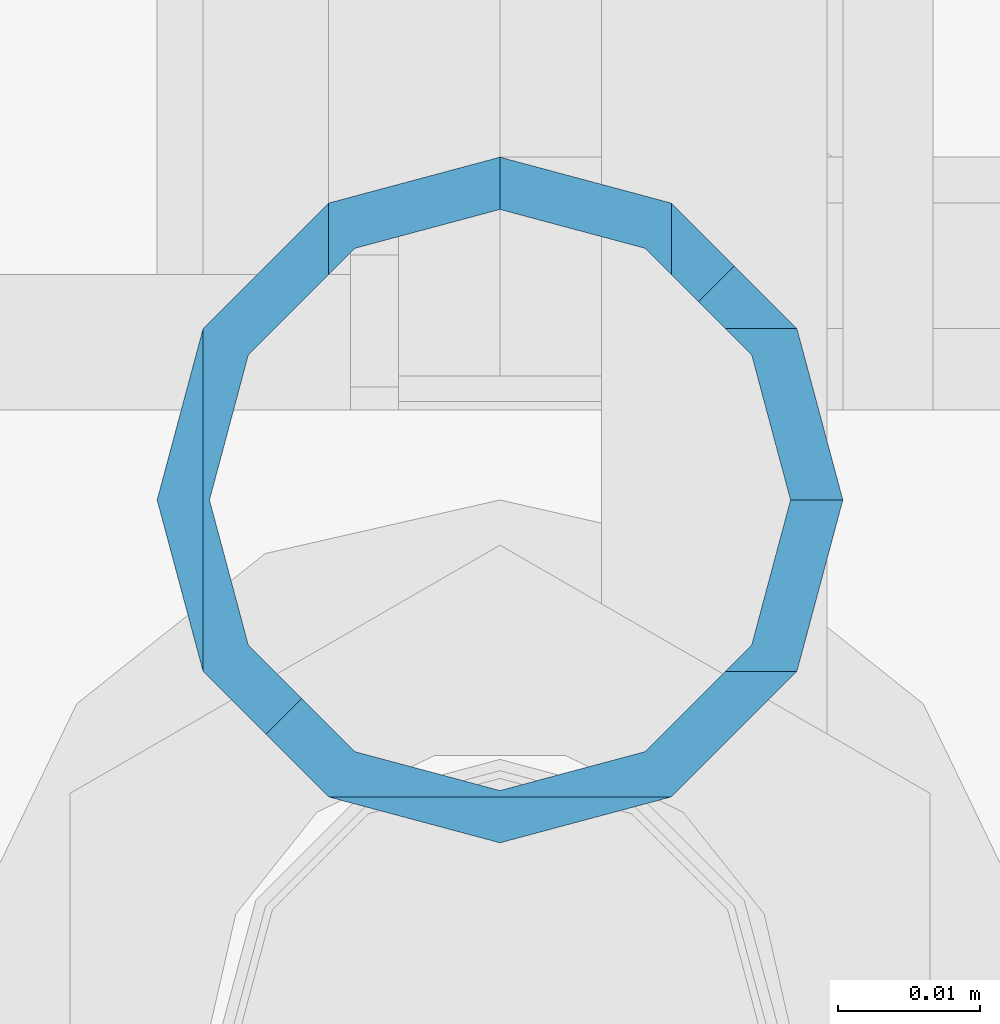
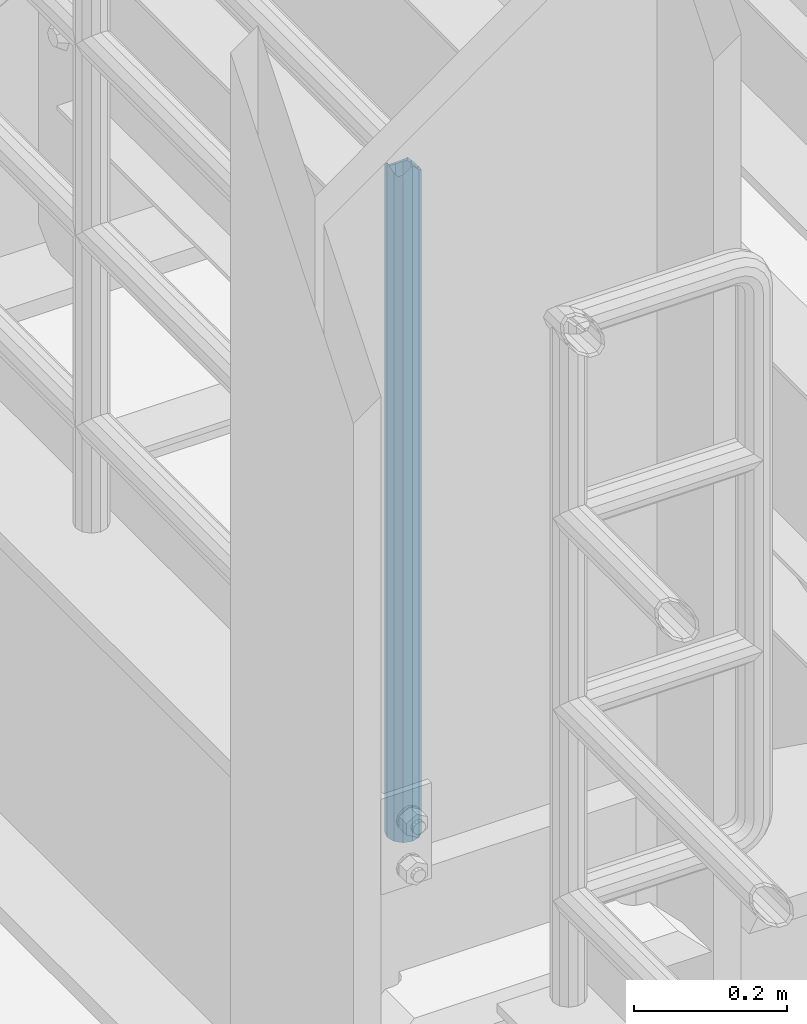
# One storey, part 596 of 1876: 1 column, 1 element without a shape of its own.
"""IFC2X3 building model written with IfcOpenShell, lengths in millimetres."""

from ifc_helpers import new_model, si_unit, frame, origin_with_axes, place, context, subcontext, project, spatial, faceted_brep, material, type_object, element, aggregate, save


model = new_model("IFC2X3")

# Units and contexts
model_context = context("Model", 3, precision=1e-05, world=origin_with_axes())
body_context = subcontext(model_context, "Body", "Model", "MODEL_VIEW")
ifc_project = project(units=[si_unit("LENGTHUNIT", "METRE", prefix="MILLI"), si_unit("AREAUNIT", "SQUARE_METRE"), si_unit("VOLUMEUNIT", "CUBIC_METRE"), si_unit("MASSUNIT", "GRAM", prefix="KILO"), si_unit("TIMEUNIT", "SECOND"), si_unit("PLANEANGLEUNIT", "RADIAN"), si_unit("SOLIDANGLEUNIT", "STERADIAN"), si_unit("THERMODYNAMICTEMPERATUREUNIT", "DEGREE_CELSIUS"), si_unit("LUMINOUSINTENSITYUNIT", "LUMEN")], contexts=[model_context])

# Site, building, storey
site_placement = place(None, origin_with_axes())
site = spatial("IfcSite", under=ifc_project, at=site_placement, CompositionType="ELEMENT")
building_placement = place(site_placement, origin_with_axes())
building = spatial("IfcBuilding", under=site, at=building_placement, Name="Undefined", CompositionType="ELEMENT")
storey_placement = place(building_placement, origin_with_axes())
storey = spatial("IfcBuildingStorey", under=building, at=storey_placement, Name="Undefined", CompositionType="ELEMENT", Elevation=0.0)

# Assembly, column
assembly_placement = place(storey_placement, origin_with_axes())
assembly = element("IfcElementAssembly", 1, at=assembly_placement, inside=storey, Name="RAIL", AssemblyPlace="NOTDEFINED", PredefinedType="RIGID_FRAME")
ifc_material = material()
column_type = type_object("IfcColumnType", Name="PIPE1-1/2SCH40", PredefinedType="NOTDEFINED")
column_placement = place(assembly_placement, frame((-3.63797880709171e-12, -4356.1, 8153.4), z_axis=(0.0, 1.0, 0.0), x_axis=(0.0, 0.0, 1.0)))
column = element("IfcColumn", 2, at=column_placement, type_object=column_type, material=ifc_material, Name="POST", ObjectType="PIPE1-1/2SCH40", context=body_context, shape_type="Brep", body=[
    faceted_brep([(1076.325, 0.0, -24.1300000000001), (1064.26, 12.065, -20.8971929933186), (1064.26, -12.0650000000001, -20.8971929933186), (1055.42780700668, -12.0650000000001, 20.8971929933186), (1055.42780700668, -12.0650000000001, 15.8661214311805), (1054.93437856882, -10.2235000000001, 17.7076214311801), (1052.195, 0.0, 20.4470000000001), (1052.195, 0.0, 24.1300000000001), (1054.93437856882, 10.2235000000001, 17.7076214311801), (1055.42780700668, 12.0650000000001, 15.8661214311805), (1055.42780700668, 12.0650000000001, 20.8971929933186), (1057.32837749183, 13.9655704718261, 13.965550959354), (1059.84391327663, 16.4811062541377, 16.4810867391807), (1055.42780700668, 15.8661214311869, 12.0649999999932), (1055.42780700668, 20.8971929933185, 12.0649999999996), (1054.93437856882, 17.7076214311801, 10.2235000000001), (1052.195, 20.4470000000001, 0.0), (1052.195, 24.13, 0.0), (1055.42780700668, 15.8661214311742, -12.065000000006), (1055.42780700668, 20.8971929933185, -12.0649999999996), (1054.93437856882, 17.7076214311801, -10.2235000000001), (1061.07042843786, 10.2235000000001, -17.7076214311801), (1063.80980700668, 0.0, -20.4470000000001), (1061.07042843786, -10.2235000000001, -17.7076214311801), (1057.32835795174, -13.9655509593522, -13.965570471828), (1059.84389372908, -16.4810867391783, -16.4811062541403), (1076.325, -24.1300000000001, 0.0), (1064.25999999999, -20.8971929933186, -12.0649999999996), (1064.26, -20.8971929933184, 12.0649999999996), (1061.07042843786, -17.7076214311803, -10.2235000000001), (1063.80980700668, -20.4469999999999, 0.0), (1061.07042843786, -17.7076214311803, 10.2235000000001), (0.0, -20.8971929933184, -12.0649999999996), (0.0, -12.0650000000001, -20.8971929933186), (-1.45519152283669e-11, 0.0, -24.130000000001), (0.0, 12.0650000000001, -20.8971929933186), (0.0, 20.8971929933184, -12.0649999999996), (0.0, 24.1299999999992, 0.0), (0.0, 20.8971929933184, 12.0649999999996), (0.0, 12.0650000000001, 20.8971929933186), (-1.45519152283669e-11, 0.0, 24.130000000001), (0.0, -12.0650000000001, 20.8971929933186), (0.0, -20.8971929933184, 12.0649999999996), (0.0, -24.1299999999992, 0.0), (0.0, -17.7076214311803, -10.2235000000001), (0.0, -10.2235000000001, -17.7076214311801), (-1.45519152283669e-11, 0.0, -20.4470000000001), (0.0, 10.2235000000001, -17.7076214311801), (0.0, 17.7076214311803, -10.2235000000001), (0.0, 20.4469999999999, 0.0), (0.0, 17.7076214311803, 10.2235000000001), (0.0, 10.2235000000001, 17.7076214311801), (-1.45519152283669e-11, 0.0, 20.4470000000001), (0.0, -10.2235000000001, 17.7076214311801), (0.0, -17.7076214311803, 10.2235000000001), (0.0, -20.4469999999999, 0.0)], [[[0, 1, 2]], [[3, 4, 5, 6, 7]], [[7, 6, 8, 9, 10]], [[10, 9, 11, 12]], [[12, 11, 13, 14]], [[15, 16, 17, 14, 13]], [[18, 19, 17, 16, 20]], [[2, 1, 19, 18, 21, 22, 23, 24, 25]], [[26, 27, 28]], [[28, 27, 25, 24, 29, 30, 31, 4, 3]], [[32, 33, 2, 25, 27]], [[33, 34, 0, 2]], [[34, 35, 1, 0]], [[35, 36, 19, 1]], [[36, 37, 17, 19]], [[37, 38, 14, 17]], [[38, 39, 10, 12, 14]], [[39, 40, 7, 10]], [[40, 41, 3, 7]], [[41, 42, 28, 3]], [[42, 43, 26, 28]], [[43, 32, 27, 26]], [[42, 41, 40, 39, 38, 37, 36, 35, 34, 33, 32, 43], [44, 45, 46, 47, 48, 49, 50, 51, 52, 53, 54, 55]], [[44, 55, 30, 29]], [[23, 45, 44, 29, 24]], [[46, 45, 23, 22]], [[47, 46, 22, 21]], [[20, 48, 47, 21, 18]], [[49, 48, 20, 16]], [[50, 49, 16, 15]], [[8, 51, 50, 15, 13, 11, 9]], [[52, 51, 8, 6]], [[53, 52, 6, 5]], [[54, 53, 5, 4, 31]], [[55, 54, 31, 30]]]),
])
aggregate(assembly, [column])

save(model, "model.ifc")
